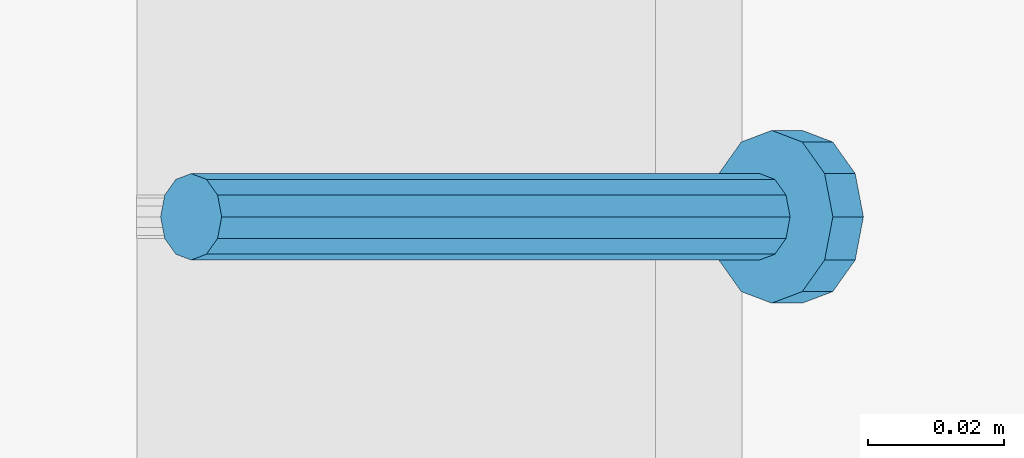
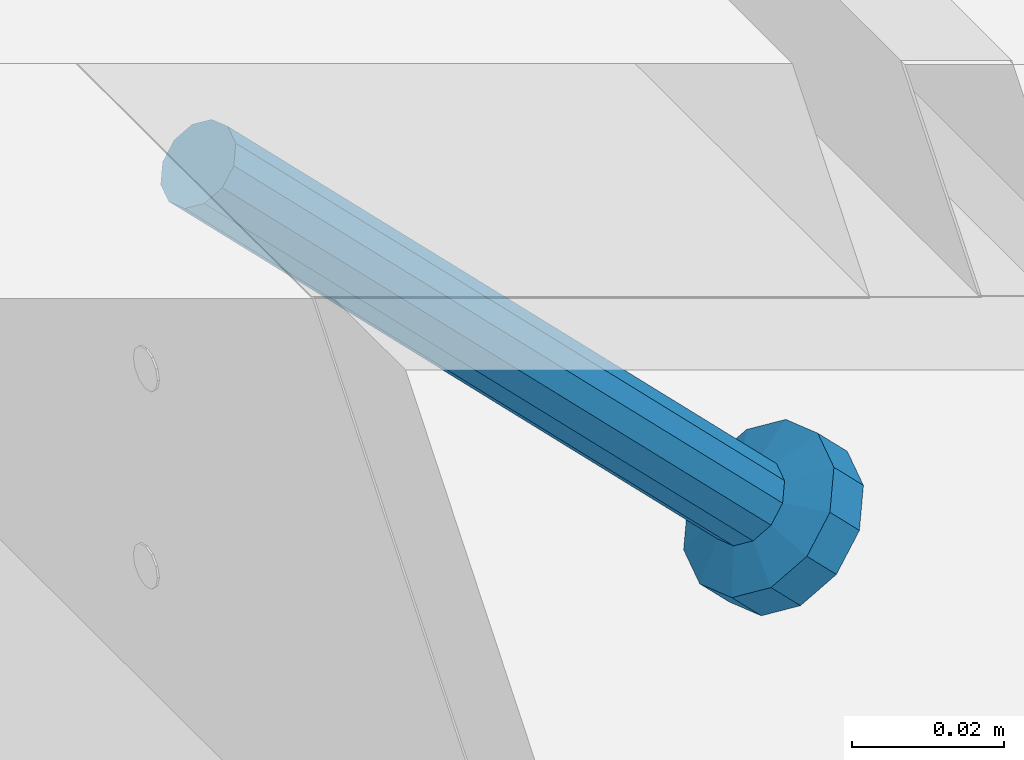
# One storey, part 2277 of 3843: 1 member, 1 element without a shape of its own.
"""IFC2X3 building model written with IfcOpenShell, lengths in millimetres."""

from ifc_helpers import new_model, si_unit, frame, origin_with_axes, place, context, subcontext, project, spatial, faceted_brep, material, type_object, element, aggregate, save


model = new_model("IFC2X3")

# Units and contexts
model_context = context("Model", 3, precision=1e-05, world=origin_with_axes())
body_context = subcontext(model_context, "Body", "Model", "MODEL_VIEW")
ifc_project = project(units=[si_unit("LENGTHUNIT", "METRE", prefix="MILLI"), si_unit("AREAUNIT", "SQUARE_METRE"), si_unit("VOLUMEUNIT", "CUBIC_METRE"), si_unit("MASSUNIT", "GRAM", prefix="KILO"), si_unit("TIMEUNIT", "SECOND"), si_unit("PLANEANGLEUNIT", "RADIAN"), si_unit("SOLIDANGLEUNIT", "STERADIAN"), si_unit("THERMODYNAMICTEMPERATUREUNIT", "DEGREE_CELSIUS"), si_unit("LUMINOUSINTENSITYUNIT", "LUMEN")], contexts=[model_context])

# Site, building, storey
site_placement = place(None, origin_with_axes())
site = spatial("IfcSite", under=ifc_project, at=site_placement, CompositionType="ELEMENT")
building_placement = place(site_placement, origin_with_axes())
building = spatial("IfcBuilding", under=site, at=building_placement, Name="Undefined", CompositionType="ELEMENT")
storey_placement = place(building_placement, origin_with_axes())
storey = spatial("IfcBuildingStorey", under=building, at=storey_placement, Name="Undefined", CompositionType="ELEMENT", Elevation=0.0)

# Assembly, member
assembly_placement = place(storey_placement, origin_with_axes())
assembly = element("IfcElementAssembly", 1, at=assembly_placement, inside=storey, Name="EMBED_ANGLE", AssemblyPlace="NOTDEFINED", PredefinedType="RIGID_FRAME")
ifc_material = material(Name="STEEL/A108")
member_type = type_object("IfcMemberType", PredefinedType="NOTDEFINED")
member_placement = place(assembly_placement, frame((66677.3495, 39598.600201416, 30446.6625), z_axis=(0.0, 1.0, 0.0), x_axis=(0.707106781186548, 0.0, -0.707106781186548)))
member = element("IfcMember", 2, at=member_placement, type_object=member_type, material=ifc_material, Name="HEADED STUD ANCHOR", context=body_context, shape_type="Brep", body=[
    faceted_brep([(7.27595761418343e-12, -3.18000006675175, 5.5), (0.0, -5.49999999998363, 3.1800000667572), (118.110000000976, -5.49999999999091, 3.1800000667572), (118.110000000983, -3.18000006675175, 5.5), (0.0, -6.3499999046162, 0.0), (118.110000000968, -6.34999990461256, 0.0), (0.0, -5.49999999998363, -3.1800000667572), (118.110000000976, -5.49999999999091, -3.1800000667572), (7.27595761418343e-12, -3.18000006675175, -5.5), (118.110000000983, -3.18000006675175, -5.5), (7.27595761418343e-12, -1.81898940354586e-12, -6.34999990463257), (118.110000000968, -1.81898940354586e-12, -6.34999990463257), (0.0, 3.18000006675175, -5.5), (118.110000000968, 3.18000006674811, -5.5), (7.27595761418343e-12, 5.49999999998363, -3.1800000667572), (118.110000000983, 5.49999999998363, -3.1800000667572), (7.27595761418343e-12, 6.3499999046162, 0.0), (118.110000000976, 6.34999990461256, 0.0), (7.27595761418343e-12, 5.49999999998363, 3.1800000667572), (118.110000000983, 5.49999999998363, 3.1800000667572), (0.0, 3.18000006675175, 5.5), (118.110000000968, 3.18000006674811, 5.5), (7.27595761418343e-12, -1.81898940354586e-12, 6.34999990463257), (118.110000000968, -1.81898940354586e-12, 6.34999990463257), (120.650000000991, -10.9899997710909, 6.34999990463257), (120.650000000998, -6.34000015257152, 10.9899997711182), (120.650000000991, -12.6999998092379, 0.0), (120.650000000991, -10.9899997710909, -6.34999990463257), (120.650000000998, -6.34000015257152, -10.9899997711182), (120.650000000991, -1.81898940354586e-12, -12.6899995803833), (120.650000000991, 6.34000015257152, -10.9899997711182), (120.650000000998, 10.9899997710909, -6.34999990463257), (120.650000000991, 12.6999998092342, 0.0), (120.650000000998, 10.9899997710909, 6.34999990463257), (120.650000000991, 6.34000015257152, 10.9899997711182), (120.650000000991, -1.81898940354586e-12, 12.6899995803833), (127.000000001048, -10.9899997710945, 6.34999990463257), (127.000000001048, -6.34000015257152, 10.9899997711182), (127.000000001048, -12.6999998092342, 0.0), (127.000000001048, -10.9899997710945, -6.34999990463257), (127.000000001048, -6.34000015257152, -10.9899997711182), (127.000000001048, 1.81898940354586e-12, -12.6899995803833), (127.000000001048, 6.34000015256788, -10.9899997711182), (127.000000001048, 10.9899997710909, -6.34999990463257), (127.000000001048, 12.6999998092379, 0.0), (127.000000001048, 10.9899997710909, 6.34999990463257), (127.000000001048, 6.34000015256788, 10.9899997711182), (127.000000001048, 1.81898940354586e-12, 12.6899995803833)], [[[0, 1, 2, 3]], [[1, 4, 5, 2]], [[4, 6, 7, 5]], [[6, 8, 9, 7]], [[8, 10, 11, 9]], [[10, 12, 13, 11]], [[12, 14, 15, 13]], [[14, 16, 17, 15]], [[16, 18, 19, 17]], [[18, 20, 21, 19]], [[20, 22, 23, 21]], [[22, 0, 3, 23]], [[22, 20, 18, 16, 14, 12, 10, 8, 6, 4, 1, 0]], [[3, 2, 24, 25]], [[2, 5, 26, 24]], [[5, 7, 27, 26]], [[7, 9, 28, 27]], [[9, 11, 29, 28]], [[11, 13, 30, 29]], [[13, 15, 31, 30]], [[15, 17, 32, 31]], [[17, 19, 33, 32]], [[19, 21, 34, 33]], [[21, 23, 35, 34]], [[23, 3, 25, 35]], [[25, 24, 36, 37]], [[24, 26, 38, 36]], [[26, 27, 39, 38]], [[27, 28, 40, 39]], [[28, 29, 41, 40]], [[29, 30, 42, 41]], [[30, 31, 43, 42]], [[31, 32, 44, 43]], [[32, 33, 45, 44]], [[33, 34, 46, 45]], [[34, 35, 47, 46]], [[35, 25, 37, 47]], [[38, 39, 40, 41, 42, 43, 44, 45, 46, 47, 37, 36]]]),
])
aggregate(assembly, [member])

save(model, "model.ifc")
